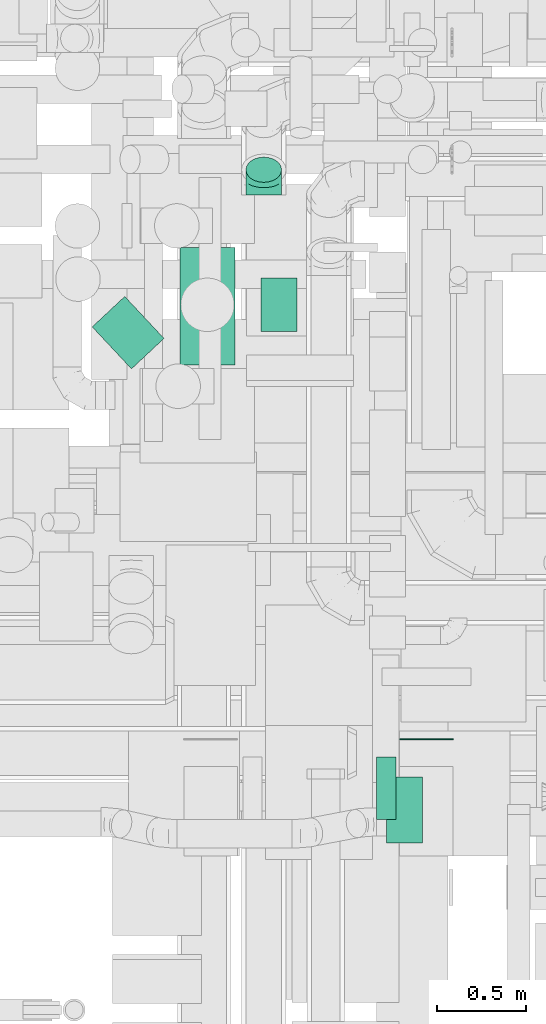
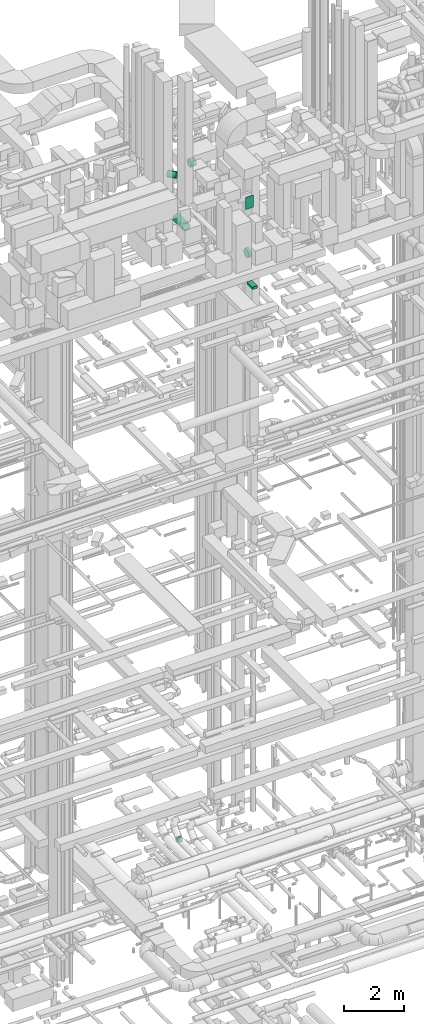
# One storey, part 182 of 337: 6 flow segments, 1 flow fitting.
"""IFC2X3 building model written with IfcOpenShell, lengths in millimetres."""

from ifc_helpers import new_model, entity, si_unit, converted_unit, derived_unit, direction, frame, origin, origin_2d_with_axis, place, context, subcontext, project, spatial, rectangle, circle, extrude, faceted_brep, source, transform, mapped, material, type_object, type_shapes, element, save


model = new_model("IFC2X3")

# Units and contexts
model_context = context("Model", 3, precision=0.01, world=origin(), true_north=direction((6.12303176911189e-17, 1.0)))
body_context = subcontext(model_context, "Body", "Model", "MODEL_VIEW")
ifc_project = project(units=[si_unit("LENGTHUNIT", "METRE", prefix="MILLI"), si_unit("AREAUNIT", "SQUARE_METRE"), si_unit("VOLUMEUNIT", "CUBIC_METRE"), converted_unit("PLANEANGLEUNIT", "DEGREE", entity("IfcRatioMeasure", 0.0174532925199433), si_unit("PLANEANGLEUNIT", "RADIAN"), dimensions=[0, 0, 0, 0, 0, 0, 0]), si_unit("MASSUNIT", "GRAM", prefix="KILO"), derived_unit("MASSDENSITYUNIT", [(si_unit("MASSUNIT", "GRAM", prefix="KILO"), 1), (si_unit("LENGTHUNIT", "METRE"), -3)]), derived_unit("MOMENTOFINERTIAUNIT", [(si_unit("LENGTHUNIT", "METRE"), 4)]), si_unit("TIMEUNIT", "SECOND"), si_unit("FREQUENCYUNIT", "HERTZ"), si_unit("THERMODYNAMICTEMPERATUREUNIT", "DEGREE_CELSIUS"), derived_unit("THERMALTRANSMITTANCEUNIT", [(si_unit("MASSUNIT", "GRAM", prefix="KILO"), 1), (si_unit("THERMODYNAMICTEMPERATUREUNIT", "KELVIN"), -1), (si_unit("TIMEUNIT", "SECOND"), -3)]), derived_unit("VOLUMETRICFLOWRATEUNIT", [(si_unit("LENGTHUNIT", "METRE"), 3), (si_unit("TIMEUNIT", "SECOND"), -1)]), derived_unit("MASSFLOWRATEUNIT", [(si_unit("MASSUNIT", "GRAM", prefix="KILO"), 1), (si_unit("TIMEUNIT", "SECOND"), -1)]), derived_unit("ROTATIONALFREQUENCYUNIT", [(si_unit("TIMEUNIT", "SECOND"), -1)]), si_unit("ELECTRICCURRENTUNIT", "AMPERE"), si_unit("ELECTRICVOLTAGEUNIT", "VOLT"), si_unit("POWERUNIT", "WATT"), si_unit("FORCEUNIT", "NEWTON", prefix="KILO"), si_unit("ILLUMINANCEUNIT", "LUX"), si_unit("LUMINOUSFLUXUNIT", "LUMEN"), si_unit("LUMINOUSINTENSITYUNIT", "CANDELA"), derived_unit("USERDEFINED", [(si_unit("MASSUNIT", "GRAM", prefix="KILO"), -1), (si_unit("LENGTHUNIT", "METRE"), -2), (si_unit("TIMEUNIT", "SECOND"), 3), (si_unit("LUMINOUSFLUXUNIT", "LUMEN"), 1)]), derived_unit("LINEARVELOCITYUNIT", [(si_unit("LENGTHUNIT", "METRE"), 1), (si_unit("TIMEUNIT", "SECOND"), -1)]), si_unit("PRESSUREUNIT", "PASCAL"), derived_unit("USERDEFINED", [(si_unit("LENGTHUNIT", "METRE"), -2), (si_unit("MASSUNIT", "GRAM", prefix="KILO"), 1), (si_unit("TIMEUNIT", "SECOND"), -2)]), derived_unit("LINEARFORCEUNIT", [(si_unit("MASSUNIT", "GRAM", prefix="KILO"), 1), (si_unit("LENGTHUNIT", "METRE"), 1), (si_unit("TIMEUNIT", "SECOND"), -2), (si_unit("LENGTHUNIT", "METRE"), -1)]), derived_unit("PLANARFORCEUNIT", [(si_unit("MASSUNIT", "GRAM", prefix="KILO"), 1), (si_unit("LENGTHUNIT", "METRE"), 1), (si_unit("TIMEUNIT", "SECOND"), -2), (si_unit("LENGTHUNIT", "METRE"), -2)])], contexts=[model_context])

# Site, building, storey
site_placement = place(None, origin())
site = spatial("IfcSite", under=ifc_project, at=site_placement, CompositionType="ELEMENT")
building_placement = place(site_placement, origin())
building = spatial("IfcBuilding", under=site, at=building_placement, CompositionType="ELEMENT")
storey_placement = place(building_placement, origin())
storey = spatial("IfcBuildingStorey", under=building, at=storey_placement, CompositionType="ELEMENT", Elevation=0.0)

# Flow segments
duct_segment_type_1 = type_object("IfcDuctSegmentType", PredefinedType="NOTDEFINED")
flow_segment_1_placement = place(storey_placement, frame((50751.67, 8083.07, 27500.0)))
element("IfcFlowSegment", 1, at=flow_segment_1_placement, inside=storey, type_object=duct_segment_type_1, context=body_context, shape_type="SweptSolid", body=[
    extrude(rectangle(XDim=369.999999999933, YDim=199.999999999998, at=origin_2d_with_axis()), frame((100.0, 185.0, 0.0), z_axis=(0.0, 0.0, 1.0), x_axis=(0.0, 1.0, 0.0)), (0.0, 0.0, 1.0), 100.000000000003),
])
flow_segment_2_placement = place(storey_placement, frame((50824.61, 8660.0, 30400.0)))
element("IfcFlowSegment", 2, at=flow_segment_2_placement, inside=storey, type_object=duct_segment_type_1, context=body_context, shape_type="SweptSolid", body=[
    extrude(rectangle(XDim=6.83947999990703, YDim=300.000000000001, at=origin_2d_with_axis()), frame((150.0, 3.42, 0.0), z_axis=(0.0, 0.0, 1.0), x_axis=(0.0, -1.0, 0.0)), (0.0, 0.0, 1.0), 499.999999999999),
])
duct_segment_type_2 = type_object("IfcDuctSegmentType", PredefinedType="NOTDEFINED")
flow_segment_3_placement = place(storey_placement, frame((50693.61, 8212.96, 28660.93)))
element("IfcFlowSegment", 3, at=flow_segment_3_placement, inside=storey, type_object=duct_segment_type_2, context=body_context, shape_type="SweptSolid", body=[
    extrude(circle(Radius=175.0, at=origin_2d_with_axis()), frame((0.0, 176.6, 176.6), z_axis=(1.0, 0.0, 0.0), x_axis=(0.0, -1.0, 0.0)), (0.0, 0.0, 1.0), 111.00000999995),
])
flow_segment_4_placement = place(storey_placement, frame((49590.28, 10762.75, 28635.9)))
element("IfcFlowSegment", 4, at=flow_segment_4_placement, inside=storey, type_object=duct_segment_type_2, context=body_context, shape_type="SweptSolid", body=[
    extrude(circle(Radius=155.0, at=origin_2d_with_axis()), frame((156.6, 0.0, 156.6), z_axis=(0.0, 1.0, 0.0), x_axis=(-1.0, 0.0, 0.0)), (0.0, 0.0, 1.0), 660.000049999984),
])
flow_segment_5_placement = place(storey_placement, frame((50046.88, 10948.65, 30948.4)))
element("IfcFlowSegment", 5, at=flow_segment_5_placement, inside=storey, type_object=duct_segment_type_2, context=body_context, shape_type="SweptSolid", body=[
    extrude(circle(Radius=150.0, at=origin_2d_with_axis()), frame((0.0, 151.6, 151.6), z_axis=(1.0, 0.0, 0.0), x_axis=(0.0, -1.0, 0.0)), (0.0, 0.0, 1.0), 202.980599999708),
])
flow_segment_6_placement = place(storey_placement, frame((49098.83, 10739.3, 30873.4)))
element("IfcFlowSegment", 6, at=flow_segment_6_placement, inside=storey, type_object=duct_segment_type_2, context=body_context, shape_type="SweptSolid", body=[
    extrude(circle(Radius=125.0, at=origin_2d_with_axis()), frame((92.88, 322.42, 126.6), z_axis=(0.683108457028695, -0.730316942112037, 0.0), x_axis=(-0.730316942112037, -0.683108457028695, 0.0)), (0.0, 0.0, 1.0), 322.371864036931),
])

# Flow fitting
ifc_material = material()
duct_fitting_type = type_object("IfcDuctFittingType", PredefinedType="NOTDEFINED", material=ifc_material)
shared_shape = source(origin(), body_context, "Body", "Brep", [
    faceted_brep([(-82.84, 0.0, -100.0), (-82.84, -25.88, -96.59), (-82.84, -50.0, -86.6), (-82.84, -70.71, -70.71), (-82.84, -86.6, -50.0), (-82.84, -96.59, -25.88), (-82.84, -100.0, 0.0), (-82.84, -96.59, 25.88), (-82.84, -86.6, 50.0), (-82.84, -70.71, 70.71), (-82.84, -50.0, 86.6), (-82.84, -25.88, 96.59), (-82.84, 0.0, 100.0), (-82.84, 25.88, 96.59), (-82.84, 50.0, 86.6), (-82.84, 70.71, 70.71), (-82.84, 86.6, 50.0), (-82.84, 96.59, 25.88), (-82.84, 100.0, 0.0), (-82.84, 96.59, -25.88), (-82.84, 86.6, -50.0), (-82.84, 70.71, -70.71), (-82.84, 50.0, -86.6), (-82.84, 25.88, -96.59), (-10.72, 25.88, 96.59), (-20.71, 50.0, 86.6), (0.0, 0.0, 100.0), (-29.29, 70.71, 70.71), (-35.87, 86.6, 50.0), (-40.01, 96.59, 25.88), (-41.42, 100.0, 0.0), (-40.01, 96.59, -25.88), (-35.87, 86.6, -50.0), (-29.29, 70.71, -70.71), (-10.72, 25.88, -96.59), (0.0, 0.0, -100.0), (-20.71, 50.0, -86.6), (10.72, -25.88, -96.59), (20.71, -50.0, -86.6), (29.29, -70.71, -70.71), (35.87, -86.6, -50.0), (40.01, -96.59, -25.88), (41.42, -100.0, 0.0), (40.01, -96.59, 25.88), (35.87, -86.6, 50.0), (29.29, -70.71, 70.71), (20.71, -50.0, 86.6), (10.72, -25.88, 96.59), (58.58, 58.58, 100.0), (40.28, 76.88, 96.59), (23.22, 93.93, 86.6), (8.58, 108.58, 70.71), (-2.66, 119.82, 50.0), (-9.72, 126.88, 25.88), (-12.13, 129.29, 0.0), (-9.72, 126.88, -25.88), (-2.66, 119.82, -50.0), (8.58, 108.58, -70.71), (23.22, 93.93, -86.6), (40.28, 76.88, -96.59), (58.58, 58.58, -100.0), (76.88, 40.28, -96.59), (93.93, 23.22, -86.6), (108.58, 8.58, -70.71), (119.82, -2.66, -50.0), (126.88, -9.72, -25.88), (129.29, -12.13, 0.0), (126.88, -9.72, 25.88), (119.82, -2.66, 50.0), (108.58, 8.58, 70.71), (93.93, 23.22, 86.6), (76.88, 40.28, 96.59)], [[[0, 1, 2, 3, 4, 5, 6, 7, 8, 9, 10, 11, 12, 13, 14, 15, 16, 17, 18, 19, 20, 21, 22, 23]], [[24, 25, 14, 13]], [[26, 24, 13, 12]], [[14, 25, 27, 15]], [[28, 29, 17, 16]], [[28, 16, 15, 27]], [[30, 18, 17, 29]], [[31, 32, 20, 19]], [[30, 31, 19, 18]], [[32, 33, 21, 20]], [[34, 35, 0, 23]], [[36, 34, 23, 22]], [[33, 36, 22, 21]], [[1, 0, 35, 37]], [[2, 1, 37, 38]], [[38, 39, 3, 2]], [[5, 4, 40, 41]], [[6, 5, 41, 42]], [[39, 40, 4, 3]], [[6, 42, 43, 7]], [[7, 43, 44, 8]], [[8, 44, 45, 9]], [[9, 45, 46, 10]], [[10, 46, 47, 11]], [[26, 12, 11, 47]], [[24, 26, 48, 49]], [[25, 24, 49, 50]], [[27, 25, 50, 51]], [[29, 28, 52, 53]], [[30, 29, 53, 54]], [[51, 52, 28, 27]], [[30, 54, 55, 31]], [[31, 55, 56, 32]], [[57, 33, 32, 56]], [[36, 58, 59, 34]], [[34, 59, 60, 35]], [[58, 36, 33, 57]], [[35, 60, 61, 37]], [[37, 61, 62, 38]], [[63, 39, 38, 62]], [[40, 64, 65, 41]], [[41, 65, 66, 42]], [[64, 40, 39, 63]], [[43, 42, 66, 67]], [[44, 43, 67, 68]], [[68, 69, 45, 44]], [[47, 46, 70, 71]], [[26, 47, 71, 48]], [[69, 70, 46, 45]], [[59, 58, 57, 56, 55, 54, 53, 52, 51, 50, 49, 48, 71, 70, 69, 68, 67, 66, 65, 64, 63, 62, 61, 60]]]),
])
type_shapes(duct_fitting_type, [shared_shape])
flow_fitting_placement = place(storey_placement, frame((50062.54, 11799.04, 3000.0), z_axis=(-1.0, 0.0, 0.0), x_axis=(0.0, -0.70710678118655, -0.707106781186545)))
element("IfcFlowFitting", 7, at=flow_fitting_placement, inside=storey, type_object=duct_fitting_type, material=ifc_material, context=body_context, shape_type="MappedRepresentation", body=[
    mapped(shared_shape, transform((0.0, 0.0, 0.0), scale=1.0)),
])

save(model, "model.ifc")
